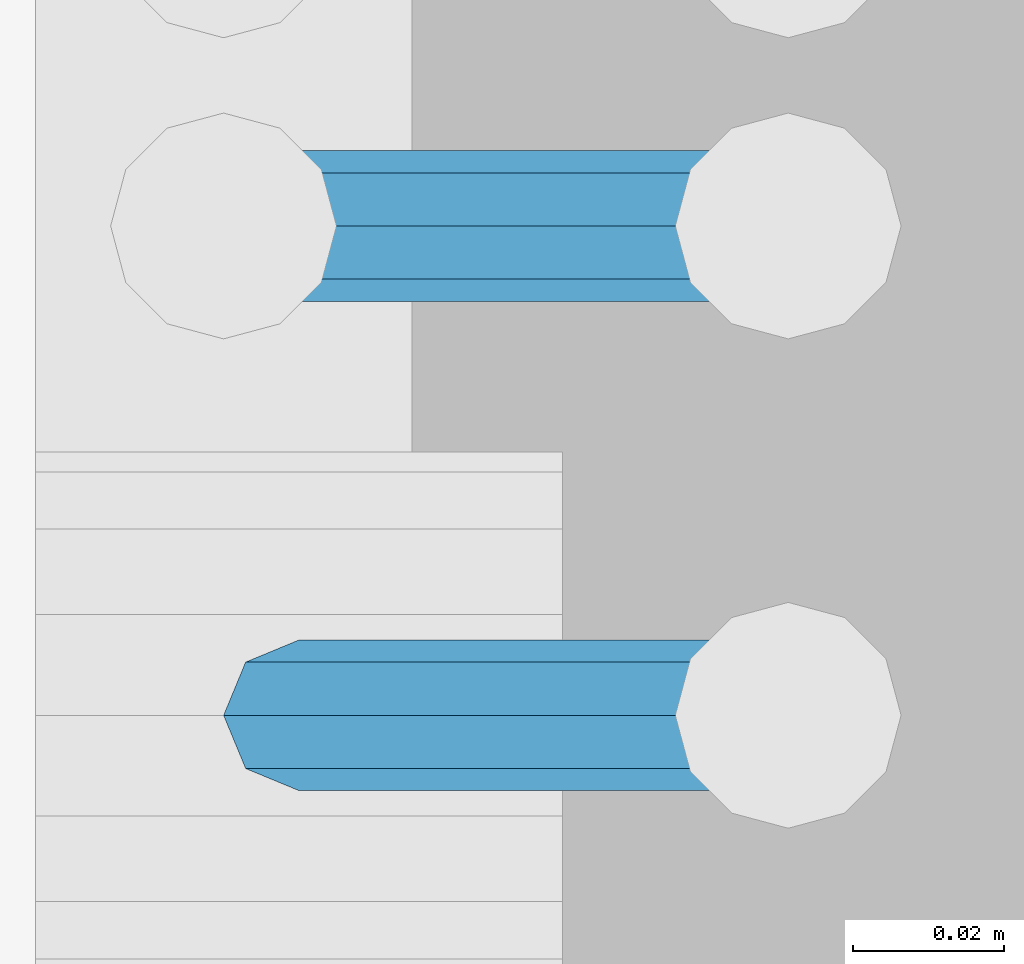
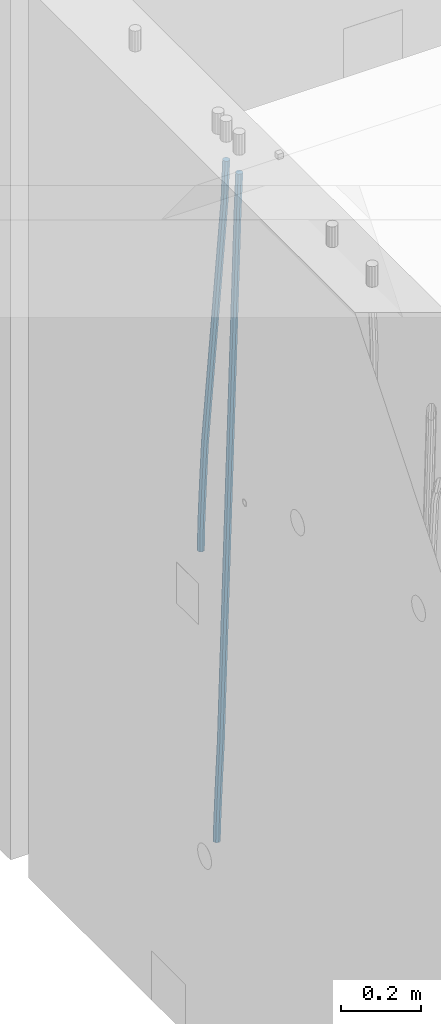
# One storey, part 105 of 350: 2 beams, 1 element without a shape of its own.
"""IFC2X3 building model written with IfcOpenShell, lengths in millimetres."""

from ifc_helpers import new_model, si_unit, frame, origin_with_axes, place, context, subcontext, project, spatial, faceted_brep, material, type_object, element, aggregate, save


model = new_model("IFC2X3")

# Units and contexts
model_context = context("Model", 3, precision=1e-05, world=origin_with_axes())
body_context = subcontext(model_context, "Body", "Model", "MODEL_VIEW")
ifc_project = project(units=[si_unit("LENGTHUNIT", "METRE", prefix="MILLI"), si_unit("AREAUNIT", "SQUARE_METRE"), si_unit("VOLUMEUNIT", "CUBIC_METRE"), si_unit("MASSUNIT", "GRAM", prefix="KILO"), si_unit("TIMEUNIT", "SECOND"), si_unit("PLANEANGLEUNIT", "RADIAN"), si_unit("SOLIDANGLEUNIT", "STERADIAN"), si_unit("THERMODYNAMICTEMPERATUREUNIT", "DEGREE_CELSIUS"), si_unit("LUMINOUSINTENSITYUNIT", "LUMEN")], contexts=[model_context])

# Site, building, storey
site_placement = place(None, origin_with_axes())
site = spatial("IfcSite", under=ifc_project, at=site_placement, CompositionType="ELEMENT")
building_placement = place(site_placement, origin_with_axes())
building = spatial("IfcBuilding", under=site, at=building_placement, CompositionType="ELEMENT")
storey_placement = place(building_placement, origin_with_axes())
storey = spatial("IfcBuildingStorey", under=building, at=storey_placement, Name="2", CompositionType="ELEMENT", Elevation=0.0)

# Assembly, beams
assembly_placement = place(storey_placement, origin_with_axes())
assembly = element("IfcElementAssembly", 1, at=assembly_placement, inside=storey, AssemblyPlace="NOTDEFINED", PredefinedType="REINFORCEMENT_UNIT")
ifc_material = material()
beam_type = type_object("IfcBeamType", Name="D20", PredefinedType="NOTDEFINED")
beam_1_placement = place(assembly_placement, frame((21736.6299977209, 11639.9999999961, 86240.97), z_axis=(0.999820284539475, 0.000205762999905157, -0.0189566949912691), x_axis=(0.0189566949945633, -3.09999984783362e-08, 0.999820305712423)))
beam_1 = element("IfcBeam", 2, at=beam_1_placement, type_object=beam_type, material=ifc_material, Name="JM20", ObjectType="D20", context=body_context, shape_type="Brep", body=[
    faceted_brep([(0.0, -10.0, 0.0), (-4.19531716033816e-08, -7.07106781186667, -7.07106781187031), (85.3814813058561, -7.07106783855306, -7.07106781027323), (85.3814813076606, -10.0000000266882, 1.58615875989199e-09), (0.0, 0.0, -10.0), (85.381481306933, -2.66882125288248e-08, -9.9999999984102), (4.196772351861e-08, 7.07106781186303, -7.07106781186667), (85.3814813102799, 7.07106778517664, -7.07106781027687), (0.0, 10.0, 0.0), (85.3814813139179, 9.99999997331361, 1.58979673869908e-09), (4.196772351861e-08, 7.07106781185939, 7.07106781185939), (85.3814813157223, 7.07106778517664, 7.07106781345647), (0.0, 0.0, 10.0), (85.3814813146601, -2.66863935394213e-08, 10.0000000015898), (-4.19531716033816e-08, -7.07106781187031, 7.07106781185939), (85.3814813113131, -7.07106783855306, 7.07106781345647), (86.0589861600893, -7.07106783876588, -7.07106781025868), (85.9854738744616, -10.0000000268774, 1.60071067512035e-09), (86.0894233170693, -2.69101292360574e-08, -9.99999999839565), (86.0589556716441, 7.07106778496563, -7.07106781026232), (85.9854307572532, 9.99999997312261, 1.60434865392745e-09), (85.9119184716255, 7.07106778501111, 7.07106781346374), (85.8814813146455, -2.68446456175298e-08, 10.0000000016007), (85.9119489600853, -7.07106783871859, 7.07106781346374), (86.7363445540104, -7.07106491765808, -7.05698116088388), (86.5893358725152, -9.99999742272485, 0.0125581869215239), (86.7972122870997, 3.02542866847944e-06, -9.98528050109235), (86.7362835792737, 7.07107070594066, -7.05698179489264), (86.5892496412271, 10.0000025770914, 0.0125572902979911), (86.4422409597319, 7.07107007202831, 7.08209663810703), (86.3813732266281, 2.12893792195246e-06, 10.0103959783119), (86.4423019344686, -7.07106555157225, 7.08209727211579), (201.576579767396, -7.07056966943492, -4.66871205216376), (201.429571085901, -9.99950217449987, 2.40082729564529), (201.637447500485, 0.00049827365182864, -7.59701139237222), (201.576518792659, 7.07156595416382, -4.66871268616887), (201.429484854598, 10.0004978253128, 2.40082639902175), (201.282476173117, 7.07156532024783, 9.47036574682716), (201.221608440013, 0.000497377159263124, 12.3986650870356), (201.282537147839, -7.07057030335091, 9.47036638083955), (202.132124882439, -7.07056727364943, -4.65715868644475), (201.96206784925, -9.99949987810942, 2.41190133749114), (202.202535595599, 0.000500710591950337, -7.58525956654921), (202.132054347894, 7.07156834990747, -4.65715951926177), (201.961968098345, 10.0005001216468, 2.41190015971006), (201.791911065156, 7.07156751718503, 9.48096018364595), (201.721500351996, 0.000499532941830694, 12.4090610637504), (201.791981599716, -7.07056810637368, 9.48096101645933), (202.687582846644, -7.07056412668317, -4.64198287962427), (202.494481077447, -9.99949686170658, 2.42644753327841), (202.767535042804, 0.000503911614941899, -7.5698230744747), (202.68750275379, 7.07157149682098, -4.64198397358632), (202.494367809079, 10.0005031379733, 2.42644598618062), (202.301266039882, 7.07157040295351, 9.4948763990833), (202.221313843707, 0.000502364651765674, 12.4227165939337), (202.301346132735, -7.07056522055063, 9.49487749304899), (324.459874135078, -7.06987422251768, -1.31501146661321), (324.266772365881, -9.99880695753927, 5.7534189462931), (324.539826331282, 0.0011938157822442, -4.24285166146001), (324.459794042268, 7.07226140098464, -1.31501256057527), (324.266659097557, 10.0011930421406, 5.75341739919895), (324.07355732836, 7.072260307119, 12.821847812098), (323.993605132171, 0.00119226882088697, 15.7496880069448), (324.07363742117, -7.06987531638515, 12.82184890606), (325.235027175528, -7.06986983086608, -1.29383331533609), (324.927897486399, -9.99880321110686, 5.771481712065), (325.36219263298, 0.00119847492351255, -4.2203835847904), (325.234900074458, 7.07226579237067, -1.29383569362108), (324.927713770478, 10.0011967881728, 5.77147824025451), (324.620584081305, 7.07226340631496, 12.8367932676701), (324.493418623882, 0.00119510052900296, 15.7633435371281), (324.620711182375, -7.06987221692179, 12.8367956459551), (326.009093599816, -7.06986028773463, -1.24766058608657), (325.588091870944, -9.99879507264814, 5.81086208727356), (326.183406134558, 0.00120859931121231, -4.1713985526585), (326.008919556407, 7.07227533492551, -1.24766576446564), (325.587845736387, 10.0012049258366, 5.81085476394219), (325.166844007501, 7.0722701409195, 12.8693774372987), (324.992531472773, 0.00120125387547887, 15.7931154038743), (325.167018050925, -7.06986548174064, 12.8693826156741), (1043.87015572292, -7.06101008762926, 41.57244298761), (1043.44915399404, -9.98994487254458, 48.6309656609665), (1044.04446825766, 0.0100587994129455, 38.6487050210344), (1043.86998167951, 7.08112553502906, 41.5724378092345), (1043.44890785948, 10.0100551259402, 48.6309583376351), (1043.02790613059, 7.08112034102305, 55.6894810109952), (1042.85359359586, 0.0100514539790311, 58.6132189775708), (1043.02808017402, -7.06101528163708, 55.6894861893743), (1044.37948441559, -7.06100380833595, 41.6028242250468), (1044.07528809507, -9.98993715320648, 48.6683142907714), (1044.54358110655, 0.0100649527612404, 38.6784768877806), (1044.47145255192, 7.08113295030489, 41.6083152880601), (1044.20535068076, 10.0100644517988, 48.6760798265532), (1043.90115436024, 7.08113110692466, 55.7415698922705), (1043.73705766928, 0.010062345829283, 58.6659172295367), (1043.80918622391, -7.06100565171619, 55.7360788292608), (1044.88956172256, -7.06765538770378, 41.6135775605035), (1044.70234249166, -9.99811415310796, 48.6815337110129), (1045.04342755441, 0.0035467872312438, 38.6890145385587), (1045.07380746971, 7.07327803990484, 41.6210139994291), (1044.96290532609, 10.0001856848303, 48.6920504237896), (1044.77568609521, 7.06972691942792, 55.7600065742954), (1044.62182026335, -0.00147525550528371, 58.6845695962329), (1044.59144034804, -7.07120650817888, 55.752570135377), (1066.60061835246, -7.35077485684633, 42.0712851901735), (1066.41339912155, -10.2812336222487, 49.1392413406866), (1066.75448418432, -0.279572681913123, 39.146722168236), (1066.78486409961, 6.79015857076047, 42.0787216290919), (1066.67396195601, 9.71706621568774, 49.1497580534597), (1066.48674272512, 6.78660745028719, 56.2177142039654), (1066.33287689326, -0.284594724647832, 59.1422772259066), (1066.30249697795, -7.3543259773196, 56.2102777650434), (1067.23595551109, -7.35905986674516, 42.0846792257544), (1067.07339946795, -10.289840248397, 49.1531553200584), (1067.33269752526, -0.287112778045412, 39.1589119322889), (1067.30695535056, 6.78335032552786, 42.0897282398291), (1067.17380840387, 9.71054805015774, 49.1602957042378), (1067.01125236072, 6.77976766850588, 56.2287717985455), (1066.91451034656, -0.292179420197499, 59.1545390920073), (1066.94025252125, -7.36264252376714, 56.2237227844671), (1067.87134798376, -7.35718323371839, 42.0978789000837), (1067.73345706461, -10.2878706396532, 49.1668746692849), (1067.91096160174, -0.285414638638031, 39.1709071780606), (1067.82909279843, 6.7848890125515, 42.1005398413035), (1067.67369920846, 9.71203973108277, 49.1706378084455), (1067.53580828934, 6.78135232514251, 56.2396335776502), (1067.49619467132, -0.290416269936031, 59.1666052996698), (1067.57806347463, -7.36071992112738, 56.2369726364304), (1167.8790332979, -7.05875998714873, 44.1723938190007), (1167.74114237876, -9.98944739308718, 51.2413895882055), (1167.9186469159, 0.0130086079316243, 41.2454220969812), (1167.83677811259, 7.08331225911934, 44.1750547602242), (1167.68138452261, 10.010462977647, 51.2451527273624), (1167.54349360349, 7.07977557171216, 58.3141484965709), (1167.50387998548, 0.00800697663180472, 61.2411202185904), (1167.58574878878, -7.06229667455955, 58.3114875553511)], [[[0, 1, 2, 3]], [[1, 4, 5, 2]], [[4, 6, 7, 5]], [[6, 8, 9, 7]], [[8, 10, 11, 9]], [[10, 12, 13, 11]], [[12, 14, 15, 13]], [[14, 0, 3, 15]], [[14, 12, 10, 8, 6, 4, 1, 0]], [[3, 2, 16, 17]], [[2, 5, 18, 16]], [[5, 7, 19, 18]], [[7, 9, 20, 19]], [[9, 11, 21, 20]], [[11, 13, 22, 21]], [[13, 15, 23, 22]], [[15, 3, 17, 23]], [[17, 16, 24, 25]], [[16, 18, 26, 24]], [[18, 19, 27, 26]], [[19, 20, 28, 27]], [[20, 21, 29, 28]], [[21, 22, 30, 29]], [[22, 23, 31, 30]], [[23, 17, 25, 31]], [[25, 24, 32, 33]], [[24, 26, 34, 32]], [[26, 27, 35, 34]], [[27, 28, 36, 35]], [[28, 29, 37, 36]], [[29, 30, 38, 37]], [[30, 31, 39, 38]], [[31, 25, 33, 39]], [[33, 32, 40, 41]], [[32, 34, 42, 40]], [[34, 35, 43, 42]], [[35, 36, 44, 43]], [[36, 37, 45, 44]], [[37, 38, 46, 45]], [[38, 39, 47, 46]], [[39, 33, 41, 47]], [[41, 40, 48, 49]], [[40, 42, 50, 48]], [[42, 43, 51, 50]], [[43, 44, 52, 51]], [[44, 45, 53, 52]], [[45, 46, 54, 53]], [[46, 47, 55, 54]], [[47, 41, 49, 55]], [[49, 48, 56, 57]], [[48, 50, 58, 56]], [[50, 51, 59, 58]], [[51, 52, 60, 59]], [[52, 53, 61, 60]], [[53, 54, 62, 61]], [[54, 55, 63, 62]], [[55, 49, 57, 63]], [[57, 56, 64, 65]], [[56, 58, 66, 64]], [[58, 59, 67, 66]], [[59, 60, 68, 67]], [[60, 61, 69, 68]], [[61, 62, 70, 69]], [[62, 63, 71, 70]], [[63, 57, 65, 71]], [[65, 64, 72, 73]], [[64, 66, 74, 72]], [[66, 67, 75, 74]], [[67, 68, 76, 75]], [[68, 69, 77, 76]], [[69, 70, 78, 77]], [[70, 71, 79, 78]], [[71, 65, 73, 79]], [[73, 72, 80, 81]], [[72, 74, 82, 80]], [[74, 75, 83, 82]], [[75, 76, 84, 83]], [[76, 77, 85, 84]], [[77, 78, 86, 85]], [[78, 79, 87, 86]], [[79, 73, 81, 87]], [[81, 80, 88, 89]], [[80, 82, 90, 88]], [[82, 83, 91, 90]], [[83, 84, 92, 91]], [[84, 85, 93, 92]], [[85, 86, 94, 93]], [[86, 87, 95, 94]], [[87, 81, 89, 95]], [[89, 88, 96, 97]], [[88, 90, 98, 96]], [[90, 91, 99, 98]], [[91, 92, 100, 99]], [[92, 93, 101, 100]], [[93, 94, 102, 101]], [[94, 95, 103, 102]], [[95, 89, 97, 103]], [[97, 96, 104, 105]], [[96, 98, 106, 104]], [[98, 99, 107, 106]], [[99, 100, 108, 107]], [[100, 101, 109, 108]], [[101, 102, 110, 109]], [[102, 103, 111, 110]], [[103, 97, 105, 111]], [[105, 104, 112, 113]], [[104, 106, 114, 112]], [[106, 107, 115, 114]], [[107, 108, 116, 115]], [[108, 109, 117, 116]], [[109, 110, 118, 117]], [[110, 111, 119, 118]], [[111, 105, 113, 119]], [[113, 112, 120, 121]], [[112, 114, 122, 120]], [[114, 115, 123, 122]], [[115, 116, 124, 123]], [[116, 117, 125, 124]], [[117, 118, 126, 125]], [[118, 119, 127, 126]], [[119, 113, 121, 127]], [[121, 120, 128, 129]], [[120, 122, 130, 128]], [[122, 123, 131, 130]], [[123, 124, 132, 131]], [[124, 125, 133, 132]], [[125, 126, 134, 133]], [[126, 127, 135, 134]], [[127, 121, 129, 135]], [[130, 131, 132, 133, 134, 135, 129, 128]]]),
])
beam_2_placement = place(assembly_placement, frame((21744.9999977209, 11574.9999999961, 85390.0), z_axis=(0.999642804629538, 0.000205762999925497, -0.0267249099901003), x_axis=(0.0267249109941254, -4.30000210532798e-08, 0.999642825779465)))
beam_2 = element("IfcBeam", 3, at=beam_2_placement, type_object=beam_type, material=ifc_material, Name="JM20", ObjectType="D20", context=body_context, shape_type="Brep", body=[
    faceted_brep([(0.0, -10.0, 0.0), (-4.19531716033816e-08, -7.07106781186667, -7.07106781187031), (60.4266690400545, -7.0710677960451, -7.07106780570757), (60.4266690441291, -9.99999998418934, 6.15546014159918e-09), (0.0, 0.0, -10.0), (60.426669036824, 1.58106558956206e-08, -9.99999999384454), (4.196772351861e-08, 7.07106781186303, -7.07106781186667), (60.4266690363438, 7.07106782768096, -7.07106780570757), (0.0, 10.0, 0.0), (60.4266690388904, 10.0000000158179, 6.15182216279209e-09), (4.196772351861e-08, 7.07106781185939, 7.07106781185939), (60.4266690429649, 7.07106782768096, 7.07106781802577), (0.0, 0.0, 10.0), (60.4266690461809, 1.58179318532348e-08, 10.0000000061555), (-4.19531716033816e-08, -7.07106781187031, 7.07106781185939), (60.4266690466611, -7.07106779605238, 7.07106781802213), (61.0378400410118, -7.07106779588503, -7.07106780564936), (60.991799419251, -9.99999998403655, 6.21366780251265e-09), (61.0569027789461, 1.5985278878361e-08, -9.99999999378269), (61.0378209396877, 7.07106782784831, -7.07106780564936), (60.9917724058905, 10.0000000159635, 6.21366780251265e-09), (60.9457317841297, 7.07106782781193, 7.0710678180767), (60.9266690461809, 1.59488990902901e-08, 10.0000000062028), (60.9457508854539, -7.07106779591413, 7.0710678180767), (61.6489592143771, -7.07106614513759, -7.06310863441468), (61.5568818710308, -9.9999984576425, 0.00735959856683621), (61.6870830769039, 1.71821739058942e-06, -9.99179257185824), (61.6489210170112, 7.07106947854481, -7.06310888312146), (61.556827851804, 10.0000015422847, 0.00735924683976918), (61.4647505084577, 7.07106922979438, 7.07782747982128), (61.4266266459163, 1.36643211590126e-06, 10.0065114172685), (61.464788705809, -7.07106639389531, 7.07782772852806), (176.543135720174, -7.07075579406956, -5.56673531796696), (176.451058376813, -9.99968810657447, 1.50373291501455), (176.581259582701, 0.000312069292704109, -8.49541925541052), (176.543097522794, 7.07137982961285, -5.56673556667374), (176.451004357587, 10.00031189336, 1.50373256329476), (176.35892701424, 7.07137958085514, 8.57420079627263), (176.320803151699, 0.000311717507429421, 11.5028847337162), (176.358965211621, -7.07075604281999, 8.57420104497578), (177.098753836006, -7.07075429323595, -5.55949898843028), (176.98362511232, -9.99968666800123, 1.510669025065), (177.146421932586, 0.000313595905026887, -8.48805862247536), (177.098706077581, 7.07138133041735, -5.55949936166144), (176.983557571715, 10.0003133318824, 1.51066849724157), (176.868428848029, 7.07138095712435, 8.58083651073321), (176.820760751449, 0.000313067976094317, 11.5093961447819), (176.868476606425, -7.07075466652896, 8.58083688396073), (177.654312950661, -7.07075204110879, -5.54863964998367), (177.516135294456, -9.99968450931192, 1.52107783331303), (177.711524267797, 0.000315886711177882, -8.47701274570863), (177.654255632195, 7.07138358250813, -5.54864021007961), (177.516054233929, 10.0003154905207, 1.5210770412159), (177.377876577739, 7.0713830223176, 8.59079452451624), (177.320665260588, 0.000315094497636892, 11.5191676202448), (177.377933896176, -7.07075260129932, 8.59079508461218), (299.529725389817, -7.0702579820354, -3.16637947698109), (299.391547733612, -9.99919045023489, 3.90333800631561), (299.586936706939, 0.000809945799119305, -6.09475257270606), (299.529668071336, 7.07187764158152, -3.16638003707703), (299.391466673056, 10.000809549605, 3.90333721422212), (299.253289016866, 7.07187708140191, 10.9730546975188), (299.196077699729, 0.000809153574664379, 13.9014277932438), (299.253346335332, -7.07025854221502, 10.9730552576111), (300.053154890193, -7.07025586015152, -3.15614816594825), (299.971788958996, -9.99918809853989, 3.91467979818117), (300.086841216093, 0.000811972313385922, -6.08498109724314), (300.053121210876, 7.07187976355999, -3.15614826397359), (299.971753863239, 10.0008119014747, 3.91467990454839), (299.890387932071, 7.07187966407218, 10.9855078686815), (299.856701606172, 0.000811831610917579, 13.9143407999763), (299.890421611388, -7.07025595963933, 10.9855079667068), (300.576681224076, -7.07025548863749, -3.15433176753868), (300.552150063115, -9.99918768617863, 3.91669348816504), (300.586838206684, 0.000812327129096957, -6.08324633496159), (300.57667118829, 7.07188013509221, -3.15433178353487), (300.552135870385, 10.0008123138141, 3.91669346554409), (300.527604709423, 7.07188011626931, 10.9877187212514), (300.517447726816, 0.000812300502730068, 13.9166332886707), (300.52761474521, -7.07025550746039, 10.9877187372476), (1894.37298527778, -7.06912446613933, 2.37541694085667), (1894.34845411681, -9.99805666368775, 9.44644219656402), (1894.3831422604, 0.00194334961997811, -0.553497626566241), (1894.37297524199, 7.07301115758673, 2.37541692486411), (1894.34843992408, 10.0019433363086, 9.44644217394307), (1894.32390876314, 7.07301113876019, 16.5174674296468), (1894.31375178052, 0.00194332300088718, 19.4463819970697), (1894.32391879891, -7.06912448496587, 16.5174674456393), (1894.94254953373, -7.06912406195261, 2.37739306992808), (1894.864138918, -9.99805629773618, 9.44823138841821), (1895.01321576146, 0.00194379674576339, -0.551311557919689), (1895.03474228333, 7.0730116272025, 2.3777129556911), (1894.99451915483, 10.0019437947958, 9.44868377519742), (1894.9161085391, 7.07301155900859, 16.5195220936839), (1894.8454423114, 0.0019437003065832, 19.4482267215244), (1894.8239157895, -7.06912413014652, 16.5192022079245), (1895.51201837322, -7.07655005247943, 2.3849721376755), (1895.3797373289, -10.0047798068154, 9.45509349396525), (1895.6431837092, -0.00627111456196872, -0.542927306803904), (1895.69639846191, 7.06438349486052, 2.38651894584837), (1895.64049015092, 9.99352020044898, 9.45728101107306), (1895.50820910657, 7.06529044610943, 16.5274023673664), (1895.37704377061, -0.00498849180803518, 19.4553018118422), (1895.3238290179, -7.07564310123053, 16.5258555591899), (1917.3375872656, -7.36115994941429, 2.67544890068893), (1917.20530622125, -10.2893897037538, 9.74557025698232), (1917.46875260158, -0.29088101150046, -0.252450543786836), (1917.52196735426, 6.77977359792203, 2.67699570887271), (1917.46605904329, 9.70891030351049, 9.74775777409013), (1917.33377799895, 6.78068054917094, 16.8178791303835), (1917.20261266298, -0.289598388742888, 19.7457785748593), (1917.1493979103, -7.36025299817265, 16.816332322207), (1917.97302879854, -7.36944623740055, 2.68390599981285), (1917.86539582294, -10.2979974076115, 9.75435539755927), (1918.04706999661, -0.298422389005282, -0.244753710507212), (1918.04414708749, 6.77296426705288, 2.68394540532245), (1917.9659722717, 9.70239133243012, 9.75441112535555), (1917.85833929609, 6.77384016221913, 16.824860523102), (1917.78429809801, -0.297183686179778, 19.753520233422), (1917.78722100714, -7.36857034223431, 16.8248211175924), (1918.60852415283, -7.36757026622581, 2.69216814523315), (1918.52554118163, -10.29602885028, 9.76294518245413), (1918.62543662851, -0.296724680512853, -0.237251666560041), (1918.56637150982, 6.77450246020453, 2.69070014292447), (1918.46592834221, 9.70388219950109, 9.76086911367383), (1918.38294537101, 6.7754236154542, 16.8316461508839), (1918.36603289531, -0.295421970262396, 19.7610659626844), (1918.42509801401, -7.36664911097978, 16.8331141531962), (2018.62930980593, -7.06930811566781, 3.98954616814444), (2018.54632683474, -9.99776669972198, 11.0603232053618), (2018.64622228162, 0.00153747004878824, 1.06012635634761), (2018.58715716293, 7.07276461076617, 3.98807816583212), (2018.4867139953, 10.0021443500664, 11.0582471365815), (2018.40373102411, 7.0736857660122, 18.1290241737915), (2018.38681854842, 0.00284018029924482, 21.0584439855957), (2018.44588366711, -7.06838696041814, 18.1304921761075)], [[[0, 1, 2, 3]], [[1, 4, 5, 2]], [[4, 6, 7, 5]], [[6, 8, 9, 7]], [[8, 10, 11, 9]], [[10, 12, 13, 11]], [[12, 14, 15, 13]], [[14, 0, 3, 15]], [[14, 12, 10, 8, 6, 4, 1, 0]], [[3, 2, 16, 17]], [[2, 5, 18, 16]], [[5, 7, 19, 18]], [[7, 9, 20, 19]], [[9, 11, 21, 20]], [[11, 13, 22, 21]], [[13, 15, 23, 22]], [[15, 3, 17, 23]], [[17, 16, 24, 25]], [[16, 18, 26, 24]], [[18, 19, 27, 26]], [[19, 20, 28, 27]], [[20, 21, 29, 28]], [[21, 22, 30, 29]], [[22, 23, 31, 30]], [[23, 17, 25, 31]], [[25, 24, 32, 33]], [[24, 26, 34, 32]], [[26, 27, 35, 34]], [[27, 28, 36, 35]], [[28, 29, 37, 36]], [[29, 30, 38, 37]], [[30, 31, 39, 38]], [[31, 25, 33, 39]], [[33, 32, 40, 41]], [[32, 34, 42, 40]], [[34, 35, 43, 42]], [[35, 36, 44, 43]], [[36, 37, 45, 44]], [[37, 38, 46, 45]], [[38, 39, 47, 46]], [[39, 33, 41, 47]], [[41, 40, 48, 49]], [[40, 42, 50, 48]], [[42, 43, 51, 50]], [[43, 44, 52, 51]], [[44, 45, 53, 52]], [[45, 46, 54, 53]], [[46, 47, 55, 54]], [[47, 41, 49, 55]], [[49, 48, 56, 57]], [[48, 50, 58, 56]], [[50, 51, 59, 58]], [[51, 52, 60, 59]], [[52, 53, 61, 60]], [[53, 54, 62, 61]], [[54, 55, 63, 62]], [[55, 49, 57, 63]], [[57, 56, 64, 65]], [[56, 58, 66, 64]], [[58, 59, 67, 66]], [[59, 60, 68, 67]], [[60, 61, 69, 68]], [[61, 62, 70, 69]], [[62, 63, 71, 70]], [[63, 57, 65, 71]], [[65, 64, 72, 73]], [[64, 66, 74, 72]], [[66, 67, 75, 74]], [[67, 68, 76, 75]], [[68, 69, 77, 76]], [[69, 70, 78, 77]], [[70, 71, 79, 78]], [[71, 65, 73, 79]], [[73, 72, 80, 81]], [[72, 74, 82, 80]], [[74, 75, 83, 82]], [[75, 76, 84, 83]], [[76, 77, 85, 84]], [[77, 78, 86, 85]], [[78, 79, 87, 86]], [[79, 73, 81, 87]], [[81, 80, 88, 89]], [[80, 82, 90, 88]], [[82, 83, 91, 90]], [[83, 84, 92, 91]], [[84, 85, 93, 92]], [[85, 86, 94, 93]], [[86, 87, 95, 94]], [[87, 81, 89, 95]], [[89, 88, 96, 97]], [[88, 90, 98, 96]], [[90, 91, 99, 98]], [[91, 92, 100, 99]], [[92, 93, 101, 100]], [[93, 94, 102, 101]], [[94, 95, 103, 102]], [[95, 89, 97, 103]], [[97, 96, 104, 105]], [[96, 98, 106, 104]], [[98, 99, 107, 106]], [[99, 100, 108, 107]], [[100, 101, 109, 108]], [[101, 102, 110, 109]], [[102, 103, 111, 110]], [[103, 97, 105, 111]], [[105, 104, 112, 113]], [[104, 106, 114, 112]], [[106, 107, 115, 114]], [[107, 108, 116, 115]], [[108, 109, 117, 116]], [[109, 110, 118, 117]], [[110, 111, 119, 118]], [[111, 105, 113, 119]], [[113, 112, 120, 121]], [[112, 114, 122, 120]], [[114, 115, 123, 122]], [[115, 116, 124, 123]], [[116, 117, 125, 124]], [[117, 118, 126, 125]], [[118, 119, 127, 126]], [[119, 113, 121, 127]], [[121, 120, 128, 129]], [[120, 122, 130, 128]], [[122, 123, 131, 130]], [[123, 124, 132, 131]], [[124, 125, 133, 132]], [[125, 126, 134, 133]], [[126, 127, 135, 134]], [[127, 121, 129, 135]], [[130, 131, 132, 133, 134, 135, 129, 128]]]),
])
aggregate(assembly, [beam_1, beam_2])

save(model, "model.ifc")
